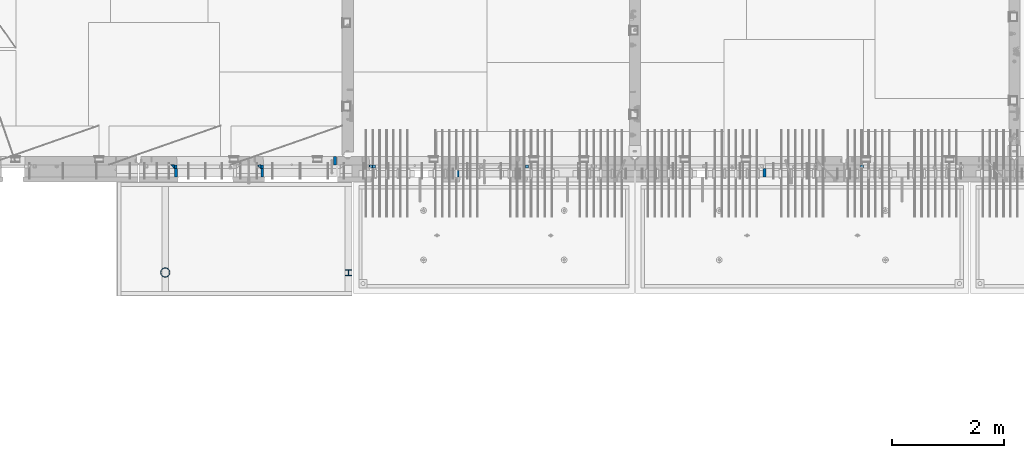
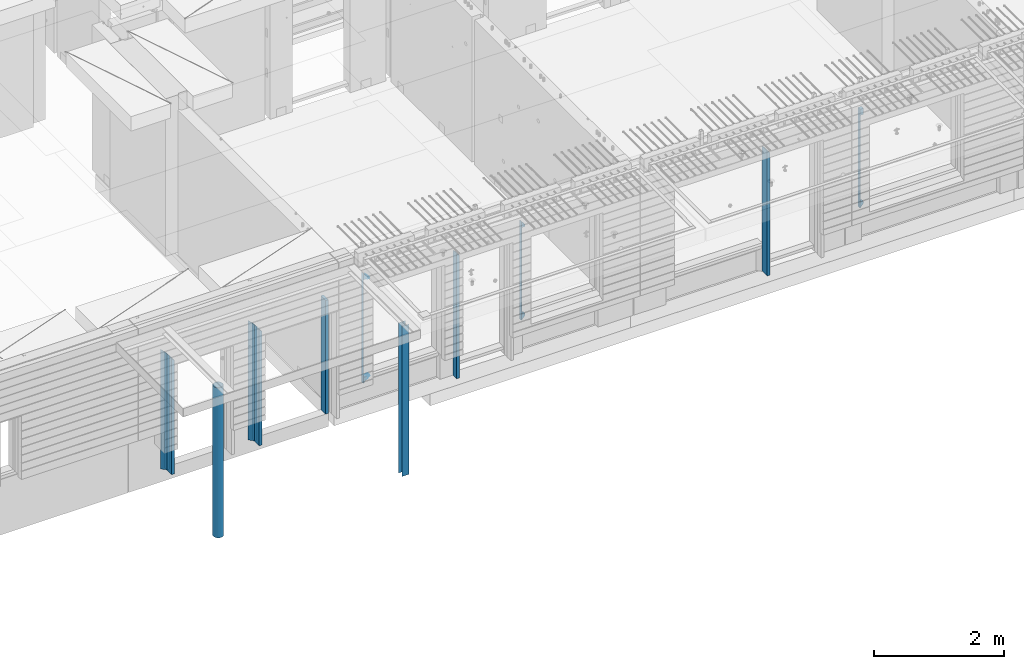
# One storey, part 2 of 325: 15 columns, 6 elements without a shape of their own.
"""IFC2X3 building model written with IfcOpenShell, lengths in millimetres."""

from ifc_helpers import new_model, si_unit, frame, origin_with_axes, place, context, subcontext, project, spatial, faceted_brep, material, type_object, element, aggregate, save


model = new_model("IFC2X3")

# Units and contexts
model_context = context("Model", 3, precision=1e-05, world=origin_with_axes())
body_context = subcontext(model_context, "Body", "Model", "MODEL_VIEW")
ifc_project = project(units=[si_unit("LENGTHUNIT", "METRE", prefix="MILLI"), si_unit("AREAUNIT", "SQUARE_METRE"), si_unit("VOLUMEUNIT", "CUBIC_METRE"), si_unit("MASSUNIT", "GRAM", prefix="KILO"), si_unit("TIMEUNIT", "SECOND"), si_unit("PLANEANGLEUNIT", "RADIAN"), si_unit("SOLIDANGLEUNIT", "STERADIAN"), si_unit("THERMODYNAMICTEMPERATUREUNIT", "DEGREE_CELSIUS"), si_unit("LUMINOUSINTENSITYUNIT", "LUMEN")], contexts=[model_context])

# Site, building, storey
site_placement = place(None, origin_with_axes())
site = spatial("IfcSite", under=ifc_project, at=site_placement, CompositionType="ELEMENT")
building_placement = place(site_placement, origin_with_axes())
building = spatial("IfcBuilding", under=site, at=building_placement, CompositionType="ELEMENT")
storey_placement = place(building_placement, origin_with_axes())
storey = spatial("IfcBuildingStorey", under=building, at=storey_placement, Name="1", CompositionType="ELEMENT", Elevation=0.0)

# Assembly, columns
assembly_1_placement = place(storey_placement, origin_with_axes())
assembly_1 = element("IfcElementAssembly", 1, at=assembly_1_placement, inside=storey, AssemblyPlace="NOTDEFINED", PredefinedType="REINFORCEMENT_UNIT")
ifc_material_1 = material(Name="CONCRETE/C25/30")
column_type_1 = type_object("IfcColumnType", PredefinedType="NOTDEFINED")
column_1_placement = place(assembly_1_placement, frame((15069.9997605339, 7815.0, 81730.0), z_axis=(1.0, 0.0, 0.0), x_axis=(0.0, 0.0, 1.0)))
column_1 = element("IfcColumn", 2, at=column_1_placement, type_object=column_type_1, material=ifc_material_1, context=body_context, shape_type="Brep", body=[
    faceted_brep([(0.0, -35.0, 35.0), (2175.00000000003, -35.0, 35.0), (2175.00000000003, 35.0, 35.0), (0.0, 35.0, 35.0), (0.0, -35.0, -35.0), (2245.0, -35.0, -35.0)], [[[0, 1, 2, 3]], [[0, 3, 4]], [[1, 0, 4, 5]], [[1, 5, 2]], [[4, 3, 2, 5]]]),
])
column_2_placement = place(assembly_1_placement, frame((13520.0003327385, 7815.0, 81730.0), z_axis=(1.0, 0.0, 0.0), x_axis=(0.0, 0.0, 1.0)))
column_2 = element("IfcColumn", 3, at=column_2_placement, type_object=column_type_1, material=ifc_material_1, context=body_context, shape_type="Brep", body=[
    faceted_brep([(0.0, -35.0, 35.0), (2175.00000000003, -35.0, 35.0), (2175.00000000003, 35.0, 35.0), (0.0, 35.0, 35.0), (0.0, -35.0, -35.0), (2245.0, -35.0, -35.0)], [[[0, 1, 2, 3]], [[0, 3, 4]], [[1, 0, 4, 5]], [[1, 5, 2]], [[4, 3, 2, 5]]]),
])
column_type_2 = type_object("IfcColumnType", PredefinedType="NOTDEFINED")
column_3_placement = place(assembly_1_placement, frame((15129.9997605339, 7815.0, 81730.0), z_axis=(1.0, 0.0, 0.0), x_axis=(0.0, 0.0, 1.0)))
column_3 = element("IfcColumn", 4, at=column_3_placement, type_object=column_type_2, material=ifc_material_1, context=body_context, shape_type="Brep", body=[
    faceted_brep([(0.0, -35.0, -25.0), (0.0, 35.0, -25.0), (2175.0, 35.0, -25.0), (2175.0, -35.0, -25.0), (0.0, -35.0, 18.8463445810194), (0.0, 35.0, 20.6412163758905), (2109.35897435897, 35.0, 20.6412163758905), (2129.35897435897, 35.0, 20.6412163758905), (20.0, 35.0, 20.6412163758905), (2131.15384615384, -35.0, 18.8463445810194), (20.0, -35.0, 18.8463445810194), (2111.15384615384, -35.0, 18.8463445810194)], [[[0, 1, 2, 3]], [[1, 0, 4, 5]], [[6, 7, 2, 1, 5, 8]], [[3, 2, 7, 9]], [[6, 8, 10, 11, 9, 7]], [[0, 3, 9, 11, 10, 4]], [[8, 5, 4, 10]]]),
])
column_4_placement = place(assembly_1_placement, frame((13580.0003327385, 7815.0, 81730.0), z_axis=(1.0, 0.0, 0.0), x_axis=(0.0, 0.0, 1.0)))
column_4 = element("IfcColumn", 5, at=column_4_placement, type_object=column_type_2, material=ifc_material_1, context=body_context, shape_type="Brep", body=[
    faceted_brep([(20.0, 35.0, 20.640071966709), (0.0, 35.0, 20.640071966709), (0.0, -35.0, 18.8452001718379), (20.0, -35.0, 18.8452001718379), (0.0, -35.0, -25.0), (0.0, 35.0, -25.0), (2175.0, 35.0, -25.0), (2175.0, -35.0, -25.0), (2129.35897435897, 35.0, 20.640071966709), (2131.15384615384, -35.0, 18.8452001718379), (2109.35897435897, 35.0, 20.640071966709), (2111.15384615384, -35.0, 18.8452001718379)], [[[0, 1, 2, 3]], [[4, 5, 6, 7]], [[7, 6, 8, 9]], [[10, 0, 3, 11, 9, 8]], [[4, 7, 9, 11, 3, 2]], [[5, 4, 2, 1]], [[10, 8, 6, 5, 1, 0]]]),
])
ifc_material_2 = material(Name="TIMBER")
column_type_3 = type_object("IfcColumnType", Name="50X150", PredefinedType="NOTDEFINED")
column_5_placement = place(assembly_1_placement, frame((16435.0003327385, 7925.0, 81730.0), z_axis=(1.0, 0.0, 0.0), x_axis=(0.0, 0.0, 1.0)))
column_5 = element("IfcColumn", 6, at=column_5_placement, type_object=column_type_3, material=ifc_material_2, ObjectType="50X150", context=body_context, shape_type="Brep", body=[
    faceted_brep([(0.0, 75.0, -25.0), (1.81898940354586e-12, 75.0, 25.0), (2130.0, 75.0, 25.0), (2130.0, 75.0, -25.0), (1.81898940354586e-12, -75.0000000000009, 25.0), (2130.0, -75.0, 25.0), (0.0, -75.0, -25.0), (2130.0, -75.0, -25.0)], [[[0, 1, 2, 3]], [[1, 4, 5, 2]], [[4, 6, 7, 5]], [[6, 0, 3, 7]], [[5, 7, 3, 2]], [[6, 4, 1, 0]]]),
])
column_6_placement = place(assembly_1_placement, frame((15129.9997605339, 7705.0, 81730.0), z_axis=(1.0, 0.0, 0.0), x_axis=(0.0, 0.0, 1.0)))
column_6 = element("IfcColumn", 7, at=column_6_placement, type_object=column_type_3, material=ifc_material_2, ObjectType="50X150", context=body_context, shape_type="Brep", body=[
    faceted_brep([(0.0, -75.0, -25.0), (1.81898940354586e-12, -75.0000000000009, 25.0), (1.81898940354586e-12, 75.0, 25.0), (0.0, 75.0, -25.0), (2125.0, -75.0, 25.0), (2125.0, 75.0, 25.0), (2175.0, 75.0, -25.0), (2175.0, -75.0, -25.0)], [[[0, 1, 2, 3]], [[2, 1, 4, 5]], [[3, 2, 5, 6]], [[0, 3, 6, 7]], [[1, 0, 7, 4]], [[6, 5, 4, 7]]]),
])
column_7_placement = place(assembly_1_placement, frame((13580.0003327385, 7705.0, 81730.0), z_axis=(1.0, 0.0, 0.0), x_axis=(0.0, 0.0, 1.0)))
column_7 = element("IfcColumn", 8, at=column_7_placement, type_object=column_type_3, material=ifc_material_2, ObjectType="50X150", context=body_context, shape_type="Brep", body=[
    faceted_brep([(0.0, -75.0, -25.0), (1.81898940354586e-12, -75.0000000000009, 25.0), (1.81898940354586e-12, 75.0, 25.0), (0.0, 75.0, -25.0), (2125.0, -75.0, 25.0), (2125.0, 75.0, 25.0), (2175.0, 75.0, -25.0), (2175.0, -75.0, -25.0)], [[[0, 1, 2, 3]], [[2, 1, 4, 5]], [[3, 2, 5, 6]], [[0, 3, 6, 7]], [[1, 0, 7, 4]], [[6, 5, 4, 7]]]),
])
aggregate(assembly_1, [column_5, column_1, column_3, column_6, column_4, column_2, column_7])

# Assembly, column
assembly_2_placement = place(storey_placement, origin_with_axes())
assembly_2 = element("IfcElementAssembly", 9, at=assembly_2_placement, inside=storey, AssemblyPlace="NOTDEFINED", PredefinedType="REINFORCEMENT_UNIT")
column_8_placement = place(assembly_2_placement, frame((24129.9998642727, 7705.0, 81760.0), z_axis=(1.0, 0.0, 0.0), x_axis=(0.0, 0.0, 1.0)))
column_8 = element("IfcColumn", 10, at=column_8_placement, type_object=column_type_3, material=ifc_material_2, ObjectType="50X150", context=body_context, shape_type="Brep", body=[
    faceted_brep([(0.0, -75.0, -25.0), (1.81898940354586e-12, -75.0000000000009, 25.0), (1.81898940354586e-12, 75.0, 25.0), (0.0, 75.0, -25.0), (2295.00000000001, -75.0, 25.0), (2295.00000000001, 75.0, 25.0), (2345.0, 75.0, -25.0), (2345.0, -75.0, -25.0)], [[[0, 1, 2, 3]], [[2, 1, 4, 5]], [[3, 2, 5, 6]], [[0, 3, 6, 7]], [[1, 0, 7, 4]], [[6, 5, 4, 7]]]),
])
aggregate(assembly_2, [column_8])

# Assembly, columns
assembly_3_placement = place(storey_placement, origin_with_axes())
assembly_3 = element("IfcElementAssembly", 11, at=assembly_3_placement, inside=storey, AssemblyPlace="NOTDEFINED", PredefinedType="REINFORCEMENT_UNIT")
ifc_material_3 = material(Name="CONCRETE/C35/45")
column_type_4 = type_object("IfcColumnType", PredefinedType="NOTDEFINED")
column_9_placement = place(assembly_3_placement, frame((17074.9994828029, 7820.0, 82120.0), z_axis=(1.0, 0.0, 0.0), x_axis=(0.0, 0.0, 1.0)))
column_9 = element("IfcColumn", 12, at=column_9_placement, type_object=column_type_4, material=ifc_material_3, Name="SK", context=body_context, shape_type="Brep", body=[
    faceted_brep([(2055.0, 30.0, -30.0), (1982.7364727329, 30.0, 30.0), (1982.7364727329, -30.0, 30.0), (2055.0, -30.0, -30.0), (1939.32432432432, 30.0, 30.0), (1940.94594594595, -30.0, 30.0), (1939.32432432432, 30.0, -24.3231799151399), (1940.94594594595, -30.0, -25.9448015367634), (115.67567567568, 30.0, -24.3231799151399), (114.054054054053, -30.0, -25.9448015367634), (114.054054054053, -30.0, 30.0), (115.67567567568, 30.0, 30.0), (72.2635272671032, -30.0, 30.0), (0.0, -30.0, -30.0), (0.0, 30.0, -30.0), (72.2635272671032, 30.0, 30.0)], [[[0, 1, 2, 3]], [[4, 5, 2, 1]], [[5, 4, 6, 7]], [[8, 9, 7, 6]], [[10, 9, 8, 11]], [[3, 2, 5, 7, 9, 10, 12, 13]], [[0, 3, 13, 14]], [[11, 8, 6, 4, 1, 0, 14, 15]], [[10, 11, 15, 12]], [[14, 13, 12, 15]]]),
])
column_10_placement = place(assembly_3_placement, frame((19875.0006272121, 7820.0, 82320.0), z_axis=(1.0, 0.0, 0.0), x_axis=(0.0, 0.0, 1.0)))
column_10 = element("IfcColumn", 13, at=column_10_placement, type_object=column_type_4, material=ifc_material_3, Name="SK", context=body_context, shape_type="Brep", body=[
    faceted_brep([(1855.0, 30.0, -30.0), (1782.73647273287, 30.0, 30.0), (1782.73647273288, -30.0, 30.0), (1855.0, -30.0, -30.0), (1739.32432432432, 30.0, 30.0), (1740.94594594595, -30.0, 30.0), (1739.32432432432, 30.0, -24.3250872637727), (1740.94594594595, -30.0, -25.9467088853962), (115.67567567568, 30.0, -24.3250872637727), (114.054054054053, -30.0, -25.9467088853962), (114.054054054053, -30.0, 30.0), (115.67567567568, 30.0, 30.0), (72.2635272671032, -30.0, 30.0), (0.0, -30.0, -30.0), (0.0, 30.0, -30.0), (72.2635272671032, 30.0, 30.0)], [[[0, 1, 2, 3]], [[4, 5, 2, 1]], [[5, 4, 6, 7]], [[8, 9, 7, 6]], [[10, 9, 8, 11]], [[3, 2, 5, 7, 9, 10, 12, 13]], [[0, 3, 13, 14]], [[11, 8, 6, 4, 1, 0, 14, 15]], [[10, 11, 15, 12]], [[14, 13, 12, 15]]]),
])

# Assembly, column
assembly_4_placement = place(storey_placement, origin_with_axes())
assembly_4 = element("IfcElementAssembly", 14, at=assembly_4_placement, inside=storey, AssemblyPlace="NOTDEFINED", PredefinedType="REINFORCEMENT_UNIT")
column_11_placement = place(assembly_4_placement, frame((25875.0006272121, 7820.0, 82320.0), z_axis=(1.0, 0.0, 0.0), x_axis=(0.0, 0.0, 1.0)))
column_11 = element("IfcColumn", 15, at=column_11_placement, type_object=column_type_4, material=ifc_material_3, Name="SK", context=body_context, shape_type="Brep", body=[
    faceted_brep([(1855.0, -30.0, 30.0), (1855.0, -30.0, -30.0), (1855.0, 30.0, -30.0), (1855.0, 30.0, 30.0), (1739.32432432432, 30.0, 30.0), (1740.94594594595, -30.0, 30.0), (1739.32432432432, 30.0, -24.3254687334993), (1740.94594594595, -30.0, -25.9470903551228), (115.67567567568, 30.0, -24.3254687334993), (114.054054054053, -30.0, -25.9470903551228), (114.054054054053, -30.0, 30.0), (115.67567567568, 30.0, 30.0), (72.2635272671032, -30.0, 30.0), (0.0, -30.0, -30.0), (0.0, 30.0, -30.0), (72.2635272671032, 30.0, 30.0)], [[[0, 1, 2, 3]], [[0, 3, 4, 5]], [[5, 4, 6, 7]], [[8, 9, 7, 6]], [[10, 9, 8, 11]], [[1, 0, 5, 7, 9, 10, 12, 13]], [[2, 1, 13, 14]], [[11, 8, 6, 4, 3, 2, 14, 15]], [[10, 11, 15, 12]], [[14, 13, 12, 15]]]),
])
aggregate(assembly_4, [column_11])

# Column
column_type_5 = type_object("IfcColumnType", PredefinedType="NOTDEFINED")
column_12_placement = place(assembly_3_placement, frame((17139.9994828029, 7820.0, 82180.0), z_axis=(1.0, 0.0, 0.0), x_axis=(0.0, 0.0, 1.0)))
column_12 = element("IfcColumn", 16, at=column_12_placement, type_object=column_type_5, material=ifc_material_3, Name="SK", context=body_context, shape_type="Brep", body=[
    faceted_brep([(1880.94594594595, -30.0, -35.0), (1879.32432432432, 30.0, -35.0), (1935.0, 30.0, -35.0), (1935.0, -30.0, -35.0), (1880.94594594595, -30.0, 18.095987949906), (1879.32432432432, 30.0, 19.6888675884147), (54.0540540540533, -30.0, -35.0), (55.6756756756804, 30.0, -35.0), (55.6756756756804, 30.0, 19.6888675884038), (54.0540540540533, -30.0, 18.0959879498987), (0.0, -30.0, -35.0), (0.0, 30.0, -35.0)], [[[0, 1, 2, 3]], [[0, 3, 4]], [[1, 0, 4, 5]], [[3, 2, 5, 4]], [[1, 5, 2]], [[6, 7, 8, 9]], [[6, 9, 10]], [[7, 6, 10, 11]], [[7, 11, 8]], [[10, 9, 8, 11]]]),
])

column_type_6 = type_object("IfcColumnType", Name="50X120", PredefinedType="NOTDEFINED")
column_13_placement = place(assembly_3_placement, frame((18629.9998642727, 7690.0, 81760.0), z_axis=(1.0, 0.0, 0.0), x_axis=(0.0, 0.0, 1.0)))
column_13 = element("IfcColumn", 17, at=column_13_placement, type_object=column_type_6, material=ifc_material_2, ObjectType="50X120", context=body_context, shape_type="Brep", body=[
    faceted_brep([(0.0, -60.0, -25.0), (0.0, -60.0, 25.0), (0.0, 60.0, 25.0), (0.0, 60.0, -25.0), (2295.00000000001, -60.0, 25.0), (2295.00000000001, 60.0, 25.0), (2345.0, 60.0, -25.0), (2345.0, -60.0, -25.0)], [[[0, 1, 2, 3]], [[2, 1, 4, 5]], [[3, 2, 5, 6]], [[0, 3, 6, 7]], [[1, 0, 7, 4]], [[6, 5, 4, 7]]]),
])

aggregate(assembly_3, [column_13, column_9, column_12, column_10])

# Assembly, column
assembly_5_placement = place(storey_placement, origin_with_axes())
assembly_5 = element("IfcElementAssembly", 18, at=assembly_5_placement, inside=storey, Name="Steel Assembly", AssemblyPlace="NOTDEFINED", PredefinedType="RIGID_FRAME")
ifc_material_4 = material(Name="STEEL/S355J2")
column_type_7 = type_object("IfcColumnType", Name="168.3X6.0", PredefinedType="NOTDEFINED")
column_14_placement = place(assembly_5_placement, frame((13389.9900452044, 5919.99723105742, 81700.0), z_axis=(-1.0, 3.00000001838171e-08, 0.0), x_axis=(0.0, 0.0, 1.0)))
column_14 = element("IfcColumn", 19, at=column_14_placement, type_object=column_type_7, material=ifc_material_4, ObjectType="168.3X6.0", context=body_context, shape_type="Brep", body=[
    faceted_brep([(0.0, -78.1499999999996, 0.0), (0.0, -75.4871033244908, 20.2267083747629), (2810.0, -75.4871033244908, 20.2267083747629), (2810.0, -78.1499999999996, 0.0), (0.0, -67.6798853057535, 39.0750000000007), (2810.0, -67.6798853057535, 39.0750000000007), (0.0, -55.2603949497288, 55.2603949497279), (2810.0, -55.2603949497288, 55.2603949497279), (0.0, -39.0749999999998, 67.6798853057535), (2810.0, -39.0749999999998, 67.6798853057535), (0.0, -20.226708374762, 75.4871033244908), (2810.0, -20.226708374762, 75.4871033244908), (0.0, 0.0, 78.1499999999996), (2810.0, 0.0, 78.1499999999996), (0.0, 20.226708374762, 75.4871033244908), (2810.0, 20.226708374762, 75.4871033244908), (0.0, 39.0749999999998, 67.6798853057535), (2810.0, 39.0749999999998, 67.6798853057535), (0.0, 55.2603949497288, 55.2603949497279), (2810.0, 55.2603949497288, 55.2603949497279), (0.0, 67.6798853057535, 39.0750000000007), (2810.0, 67.6798853057535, 39.0750000000007), (0.0, 75.4871033244908, 20.2267083747611), (2810.0, 75.4871033244908, 20.2267083747611), (0.0, 78.1499999999996, 0.0), (2810.0, 78.1499999999996, 0.0), (0.0, 75.4871033244908, -20.2267083747629), (2810.0, 75.4871033244908, -20.2267083747629), (0.0, 67.6798853057535, -39.0750000000007), (2810.0, 67.6798853057535, -39.0750000000007), (0.0, 55.2603949497288, -55.2603949497279), (2810.0, 55.2603949497288, -55.2603949497279), (0.0, 39.0749999999998, -67.6798853057535), (2810.0, 39.0749999999998, -67.6798853057535), (0.0, 20.226708374762, -75.4871033244908), (2810.0, 20.226708374762, -75.4871033244908), (0.0, 0.0, -78.1499999999996), (2810.0, 0.0, -78.1499999999996), (0.0, -20.226708374762, -75.4871033244908), (2810.0, -20.226708374762, -75.4871033244908), (0.0, -39.0749999999998, -67.6798853057535), (2810.0, -39.0749999999998, -67.6798853057535), (0.0, -55.2603949497288, -55.2603949497279), (2810.0, -55.2603949497288, -55.2603949497279), (0.0, -67.6798853057535, -39.0750000000007), (2810.0, -67.6798853057535, -39.0750000000007), (0.0, -75.4871033244908, -20.2267083747629), (2810.0, -75.4871033244908, -20.2267083747629), (0.0, -84.1499999999996, 0.0), (0.0, -81.2826582822254, -21.7796226453775), (2810.0, -81.2826582822254, -21.7796226453775), (2810.0, -84.1499999999996, 0.0), (0.0, -72.8760377284607, -42.0750000000007), (2810.0, -72.8760377284607, -42.0750000000007), (0.0, -59.5030356368479, -59.5030356368479), (2810.0, -59.5030356368479, -59.5030356368479), (0.0, -42.0749999999998, -72.8760377284598), (2810.0, -42.0749999999998, -72.8760377284598), (0.0, -21.7796226453775, -81.2826582822254), (2810.0, -21.7796226453775, -81.2826582822254), (0.0, 0.0, -84.1499999999996), (2810.0, 0.0, -84.1499999999996), (0.0, 21.7796226453775, -81.2826582822254), (2810.0, 21.7796226453775, -81.2826582822254), (0.0, 42.0749999999998, -72.8760377284598), (2810.0, 42.0749999999998, -72.8760377284598), (0.0, 59.5030356368479, -59.5030356368479), (2810.0, 59.5030356368479, -59.5030356368479), (0.0, 72.8760377284607, -42.0750000000007), (2810.0, 72.8760377284607, -42.0750000000007), (0.0, 81.2826582822254, -21.7796226453775), (2810.0, 81.2826582822254, -21.7796226453775), (0.0, 84.1499999999996, 0.0), (2810.0, 84.1499999999996, 0.0), (0.0, 81.2826582822254, 21.7796226453775), (2810.0, 81.2826582822254, 21.7796226453775), (0.0, 72.8760377284607, 42.0750000000007), (2810.0, 72.8760377284607, 42.0750000000007), (0.0, 59.5030356368479, 59.5030356368479), (2810.0, 59.5030356368479, 59.5030356368479), (0.0, 42.0749999999998, 72.8760377284598), (2810.0, 42.0749999999998, 72.8760377284598), (0.0, 21.7796226453775, 81.2826582822254), (2810.0, 21.7796226453775, 81.2826582822254), (0.0, 0.0, 84.1499999999996), (2810.0, 0.0, 84.1499999999996), (0.0, -21.7796226453775, 81.2826582822254), (2810.0, -21.7796226453775, 81.2826582822254), (0.0, -42.0749999999998, 72.8760377284598), (2810.0, -42.0749999999998, 72.8760377284598), (0.0, -59.5030356368479, 59.5030356368479), (2810.0, -59.5030356368479, 59.5030356368479), (0.0, -72.8760377284607, 42.0750000000007), (2810.0, -72.8760377284607, 42.0750000000007), (0.0, -81.2826582822254, 21.7796226453775), (2810.0, -81.2826582822254, 21.7796226453775)], [[[0, 1, 2, 3]], [[1, 4, 5, 2]], [[4, 6, 7, 5]], [[6, 8, 9, 7]], [[8, 10, 11, 9]], [[10, 12, 13, 11]], [[12, 14, 15, 13]], [[14, 16, 17, 15]], [[16, 18, 19, 17]], [[18, 20, 21, 19]], [[20, 22, 23, 21]], [[22, 24, 25, 23]], [[24, 26, 27, 25]], [[26, 28, 29, 27]], [[28, 30, 31, 29]], [[30, 32, 33, 31]], [[32, 34, 35, 33]], [[34, 36, 37, 35]], [[36, 38, 39, 37]], [[38, 40, 41, 39]], [[40, 42, 43, 41]], [[42, 44, 45, 43]], [[44, 46, 47, 45]], [[46, 0, 3, 47]], [[48, 49, 50, 51]], [[49, 52, 53, 50]], [[52, 54, 55, 53]], [[54, 56, 57, 55]], [[56, 58, 59, 57]], [[58, 60, 61, 59]], [[60, 62, 63, 61]], [[62, 64, 65, 63]], [[64, 66, 67, 65]], [[66, 68, 69, 67]], [[68, 70, 71, 69]], [[70, 72, 73, 71]], [[72, 74, 75, 73]], [[74, 76, 77, 75]], [[76, 78, 79, 77]], [[78, 80, 81, 79]], [[80, 82, 83, 81]], [[82, 84, 85, 83]], [[84, 86, 87, 85]], [[86, 88, 89, 87]], [[88, 90, 91, 89]], [[90, 92, 93, 91]], [[92, 94, 95, 93]], [[94, 48, 51, 95]], [[53, 55, 57, 59, 61, 63, 65, 67, 69, 71, 73, 75, 77, 79, 81, 83, 85, 87, 89, 91, 93, 95, 51, 50], [5, 7, 9, 11, 13, 15, 17, 19, 21, 23, 25, 27, 29, 31, 33, 35, 37, 39, 41, 43, 45, 47, 3, 2]], [[94, 92, 90, 88, 86, 84, 82, 80, 78, 76, 74, 72, 70, 68, 66, 64, 62, 60, 58, 56, 54, 52, 49, 48], [46, 44, 42, 40, 38, 36, 34, 32, 30, 28, 26, 24, 22, 20, 18, 16, 14, 12, 10, 8, 6, 4, 1, 0]]]),
])
aggregate(assembly_5, [column_14])

assembly_6_placement = place(storey_placement, origin_with_axes())
assembly_6 = element("IfcElementAssembly", 20, at=assembly_6_placement, inside=storey, Name="Steel Assembly", AssemblyPlace="NOTDEFINED", PredefinedType="RIGID_FRAME")
column_type_8 = type_object("IfcColumnType", Name="HEA120", PredefinedType="NOTDEFINED")
column_15_placement = place(assembly_6_placement, frame((16674.9969641497, 5915.00311728789, 81700.0), z_axis=(0.0, 1.0, 0.0), x_axis=(0.0, 0.0, 1.0)))
column_15 = element("IfcColumn", 21, at=column_15_placement, type_object=column_type_8, material=ifc_material_4, ObjectType="HEA120", context=body_context, shape_type="Brep", body=[
    faceted_brep([(0.0, 60.0, -57.0), (0.0, 60.0, -49.0), (2810.0, 60.0, -49.0), (2810.0, 60.0, -57.0), (0.0, 2.5, -49.0), (2810.0, 2.5, -49.0), (0.0, 2.5, 49.0), (2810.0, 2.5, 49.0), (0.0, 60.0, 49.0), (2810.0, 60.0, 49.0), (0.0, 60.0, 57.0), (2810.0, 60.0, 57.0), (0.0, -60.0, 57.0), (2810.0, -60.0, 57.0), (0.0, -60.0, 49.0), (2810.0, -60.0, 49.0), (0.0, -2.5, 49.0), (2810.0, -2.5, 49.0), (0.0, -2.5, -49.0), (2810.0, -2.5, -49.0), (0.0, -60.0, -49.0), (2810.0, -60.0, -49.0), (0.0, -60.0, -57.0), (2810.0, -60.0, -57.0)], [[[0, 1, 2, 3]], [[1, 4, 5, 2]], [[4, 6, 7, 5]], [[6, 8, 9, 7]], [[8, 10, 11, 9]], [[10, 12, 13, 11]], [[12, 14, 15, 13]], [[14, 16, 17, 15]], [[16, 18, 19, 17]], [[18, 20, 21, 19]], [[20, 22, 23, 21]], [[22, 0, 3, 23]], [[5, 7, 9, 11, 13, 15, 17, 19, 21, 23, 3, 2]], [[22, 20, 18, 16, 14, 12, 10, 8, 6, 4, 1, 0]]]),
])
aggregate(assembly_6, [column_15])

save(model, "model.ifc")
